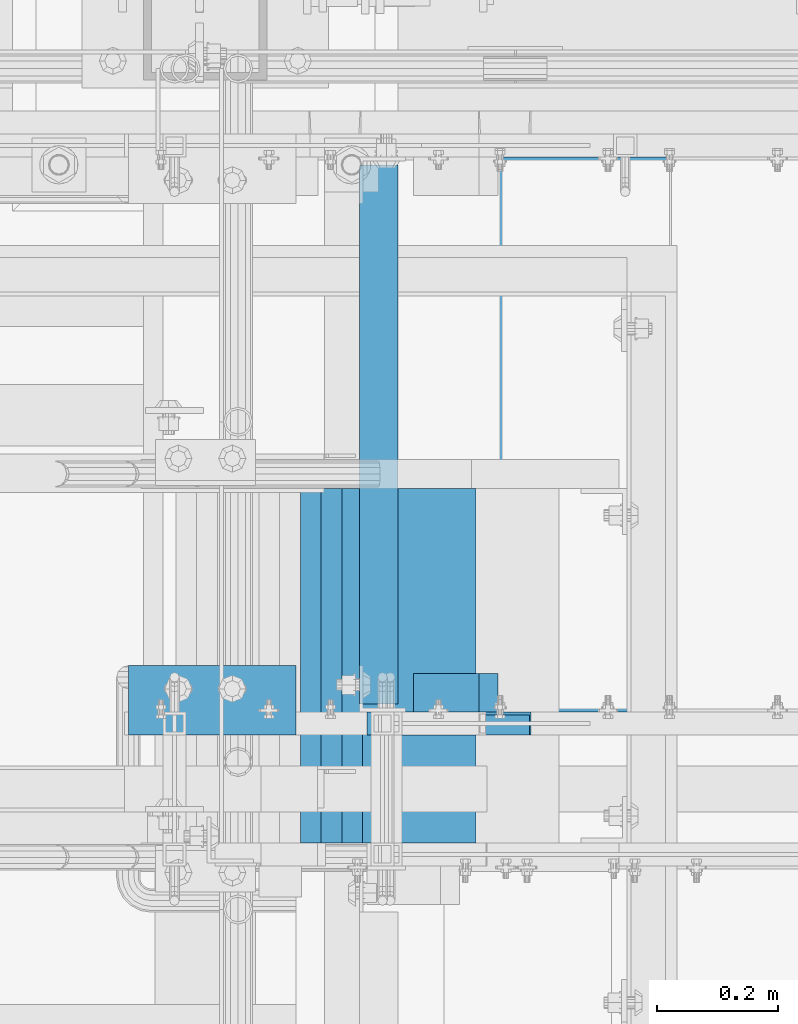
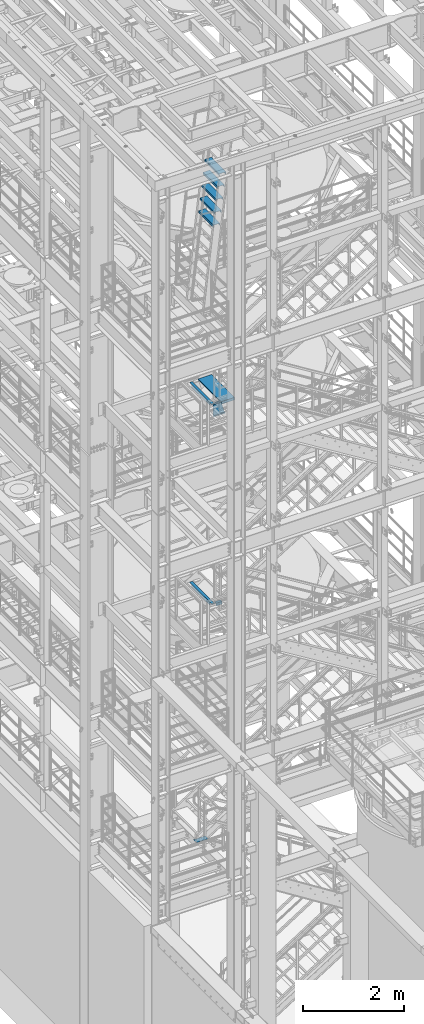
# One storey, part 1168 of 1876: 12 beams, 6 elements without a shape of their own.
"""IFC2X3 building model written with IfcOpenShell, lengths in millimetres."""

from ifc_helpers import new_model, si_unit, frame, origin_with_axes, place, context, subcontext, project, spatial, faceted_brep, material, type_object, element, aggregate, save


model = new_model("IFC2X3")

# Units and contexts
model_context = context("Model", 3, precision=1e-05, world=origin_with_axes())
body_context = subcontext(model_context, "Body", "Model", "MODEL_VIEW")
ifc_project = project(units=[si_unit("LENGTHUNIT", "METRE", prefix="MILLI"), si_unit("AREAUNIT", "SQUARE_METRE"), si_unit("VOLUMEUNIT", "CUBIC_METRE"), si_unit("MASSUNIT", "GRAM", prefix="KILO"), si_unit("TIMEUNIT", "SECOND"), si_unit("PLANEANGLEUNIT", "RADIAN"), si_unit("SOLIDANGLEUNIT", "STERADIAN"), si_unit("THERMODYNAMICTEMPERATUREUNIT", "DEGREE_CELSIUS"), si_unit("LUMINOUSINTENSITYUNIT", "LUMEN")], contexts=[model_context])

# Site, building, storey
site_placement = place(None, origin_with_axes())
site = spatial("IfcSite", under=ifc_project, at=site_placement, CompositionType="ELEMENT")
building_placement = place(site_placement, origin_with_axes())
building = spatial("IfcBuilding", under=site, at=building_placement, Name="Undefined", CompositionType="ELEMENT")
storey_placement = place(building_placement, origin_with_axes())
storey = spatial("IfcBuildingStorey", under=building, at=storey_placement, Name="Undefined", CompositionType="ELEMENT", Elevation=0.0)

# Assembly, beam
assembly_1_placement = place(storey_placement, origin_with_axes())
assembly_1 = element("IfcElementAssembly", 1, at=assembly_1_placement, inside=storey, Name="STRINGER", AssemblyPlace="NOTDEFINED", PredefinedType="RIGID_FRAME")
ifc_material = material(Name="STEEL/A36")
beam_type_1 = type_object("IfcBeamType", Name="L2-1/2X2-1/2X1/4", PredefinedType="NOTDEFINED")
beam_1_placement = place(assembly_1_placement, frame((2178.05007328855, -5683.25000115264, 15531.2768519598), z_axis=(0.0, 1.0, 0.0), x_axis=(-1.0, 0.0, 0.0)))
beam_1 = element("IfcBeam", 2, at=beam_1_placement, type_object=beam_type_1, material=ifc_material, Name="STRINGER", ObjectType="L2-1/2X2-1/2X1/4", context=body_context, shape_type="Brep", body=[
    faceted_brep([(0.0, 31.75, -31.75), (0.0, 31.75, 31.75), (107.95007324219, 31.7500000000491, 31.75), (107.95007324219, 31.7500000000491, -31.75), (0.0, 25.3999999999996, 31.75), (107.950073242189, 25.4000000000487, 31.75), (0.0, 25.3999999999996, -25.3999999999996), (107.950073242189, 25.4000000000487, -25.3999999999996), (0.0, -31.75, -25.3999999999996), (107.950073242189, -31.7499999999509, -25.3999999999996), (0.0, -31.75, -31.75), (107.950073242189, -31.7499999999509, -31.75)], [[[0, 1, 2, 3]], [[1, 4, 5, 2]], [[4, 6, 7, 5]], [[6, 8, 9, 7]], [[8, 10, 11, 9]], [[10, 0, 3, 11]], [[5, 7, 9, 11, 3, 2]], [[10, 8, 6, 4, 1, 0]]]),
])

assembly_2_placement = place(storey_placement, origin_with_axes())
assembly_2 = element("IfcElementAssembly", 3, at=assembly_2_placement, inside=storey, Name="STRINGER", AssemblyPlace="NOTDEFINED", PredefinedType="RIGID_FRAME")
beam_2_placement = place(assembly_2_placement, frame((2012.95, -4813.30000114601, 15531.3367791615), z_axis=(0.0, 0.0, -1.0), x_axis=(0.0, -1.0, 0.0)))
beam_2 = element("IfcBeam", 4, at=beam_2_placement, type_object=beam_type_1, material=ifc_material, Name="STRINGER", ObjectType="L2-1/2X2-1/2X1/4", context=body_context, shape_type="Brep", body=[
    faceted_brep([(76.1999938964764, 25.4000000000001, -19.0499992370624), (76.1999938964764, 31.75, -19.0499992370624), (0.0, 31.75, -19.0499992370605), (0.0, 25.4000000000001, -19.0499992370605), (76.1999938964791, 25.4000000000001, 31.7499999999982), (76.1999938964791, 31.75, 31.75), (0.0, 25.3999999999996, -25.3999999999996), (0.0, -31.75, -25.3999999999996), (889.000000006634, -31.75, -25.3999999999996), (889.000000006634, 25.4000000000001, -25.3999999999996), (0.0, -31.75, -31.75), (889.000000006634, -31.75, -31.75), (0.0, 31.75, -31.75), (889.000000006634, 31.75, -31.75), (889.000000006634, 31.75, -19.0499992370569), (889.000000006633, 25.4000000000001, -19.0499992370569), (812.800003058393, 31.75, -19.0499992370569), (812.800003058393, 25.4000000000001, -19.0499992370569), (812.800003058393, 25.4000000000001, 31.75), (812.800003058393, 31.75, 31.75)], [[[0, 1, 2, 3]], [[4, 5, 1, 0]], [[6, 7, 8, 9]], [[7, 10, 11, 8]], [[10, 12, 13, 11]], [[9, 8, 11, 13, 14, 15]], [[15, 14, 16, 17]], [[18, 17, 16, 19]], [[3, 6, 9, 15, 17, 18, 4, 0]], [[12, 10, 7, 6, 3, 2]], [[19, 16, 14, 13, 12, 2, 1, 5]], [[18, 19, 5, 4]]]),
])
aggregate(assembly_2, [beam_2])

assembly_3_placement = place(storey_placement, origin_with_axes())
assembly_3 = element("IfcElementAssembly", 5, at=assembly_3_placement, inside=storey, Name="STRINGER", AssemblyPlace="NOTDEFINED", PredefinedType="RIGID_FRAME")
beam_3_placement = place(assembly_3_placement, frame((2209.80007358444, -5683.25000115213, 10702.925), z_axis=(0.0, 1.0, 0.0), x_axis=(-1.0, 0.0, 0.0)))
beam_3 = element("IfcBeam", 6, at=beam_3_placement, type_object=beam_type_1, material=ifc_material, Name="ANGLE", ObjectType="L2-1/2X2-1/2X1/4", context=body_context, shape_type="Brep", body=[
    faceted_brep([(0.0, 31.75, -31.75), (0.0, 31.75, 31.75), (139.700073242188, 31.75, 31.75), (139.700073242188, 31.75, -31.75), (0.0, 25.3999999999996, 31.75), (139.700073242188, 25.3999999999996, 31.75), (0.0, 25.3999999999996, -25.3999999999996), (139.700073242188, 25.3999999999996, -25.3999999999996), (0.0, -31.75, -25.3999999999996), (139.700073242188, -31.75, -25.3999999999996), (0.0, -31.75, -31.75), (139.700073242188, -31.75, -31.75)], [[[0, 1, 2, 3]], [[1, 4, 5, 2]], [[4, 6, 7, 5]], [[6, 8, 9, 7]], [[8, 10, 11, 9]], [[10, 0, 3, 11]], [[5, 7, 9, 11, 3, 2]], [[10, 8, 6, 4, 1, 0]]]),
])
aggregate(assembly_3, [beam_3])

assembly_4_placement = place(storey_placement, origin_with_axes())
assembly_4 = element("IfcElementAssembly", 7, at=assembly_4_placement, inside=storey, Name="STRINGER", AssemblyPlace="NOTDEFINED", PredefinedType="RIGID_FRAME")
beam_4_placement = place(assembly_4_placement, frame((2012.95000034225, -4813.3000011455, 10702.925), z_axis=(0.0, 0.0, -1.0), x_axis=(0.0, -1.0, 0.0)))
beam_4 = element("IfcBeam", 8, at=beam_4_placement, type_object=beam_type_1, material=ifc_material, Name="STRINGER", ObjectType="L2-1/2X2-1/2X1/4", context=body_context, shape_type="Brep", body=[
    faceted_brep([(76.1999938964764, 25.4000000000001, -19.0499992370624), (76.1999938964764, 31.75, -19.0499992370624), (0.0, 31.75, -19.0499992370605), (0.0, 25.4000000000001, -19.0499992370605), (76.1999938964791, 25.4000000000001, 31.7499999999982), (76.1999938964791, 31.75, 31.75), (0.0, 25.3999999999996, -25.3999999999996), (0.0, -31.75, -25.3999999999996), (889.000000006634, -31.75, -25.3999999999996), (889.000000006634, 25.4000000000001, -25.3999999999996), (0.0, -31.75, -31.75), (889.000000006634, -31.75, -31.75), (0.0, 31.75, -31.75), (889.000000006634, 31.75, -31.75), (889.000000006634, 31.75, -19.0499992370569), (889.000000006633, 25.4000000000001, -19.0499992370569), (812.800003058393, 31.75, -19.0499992370569), (812.800003058393, 25.4000000000001, -19.0499992370569), (812.800003058393, 25.4000000000001, 31.75), (812.800003058393, 31.75, 31.75)], [[[0, 1, 2, 3]], [[4, 5, 1, 0]], [[6, 7, 8, 9]], [[7, 10, 11, 8]], [[10, 12, 13, 11]], [[9, 8, 11, 13, 14, 15]], [[15, 14, 16, 17]], [[18, 17, 16, 19]], [[3, 6, 9, 15, 17, 18, 4, 0]], [[12, 10, 7, 6, 3, 2]], [[19, 16, 14, 13, 12, 2, 1, 5]], [[18, 19, 5, 4]]]),
])
aggregate(assembly_4, [beam_4])

# Beam
beam_type_2 = type_object("IfcBeamType", PredefinedType="NOTDEFINED")
beam_5_placement = place(assembly_1_placement, frame((2338.38750025482, -4805.36200114421, 15559.8518518519), z_axis=(-1.0, 0.0, 0.0), x_axis=(0.0, -1.0, 0.0)))
beam_5 = element("IfcBeam", 9, at=beam_5_placement, type_object=beam_type_2, material=ifc_material, Name="TREAD", context=body_context, shape_type="Brep", body=[
    faceted_brep([(-4.76199999866458, -53.9750000000076, -153.987499894642), (-4.76199999866458, -53.9750000000076, 153.987506208874), (-4.76199999866458, 9.52499999999782, 153.987536726452), (-4.76199999866458, 9.52499999999236, -153.987499894642), (1.33604771690443e-09, -53.9750000000076, -153.987499894642), (1.33604771690443e-09, -53.9750000000076, 153.987506208874), (1.33604771690443e-09, -9.52499999999964, -153.987499894642), (-7.45785655453801e-11, -9.52500000019427, 153.987536621094), (909.637999997837, 9.52499999999236, -153.987499894642), (0.0, 9.52499999999964, 153.9875), (909.637999997837, 9.52499999999236, 153.987506208874), (909.637999997837, -53.9750000000076, -153.987499894642), (904.875999997837, -53.9750000000076, -153.987499894642), (904.875999997837, -9.52499999999964, -153.9875), (904.875999997837, -9.52499999999964, 153.987506208874), (904.875999997837, -53.9750000000076, 153.987506208874), (909.637999997837, -53.9750000000076, 153.987506208874)], [[[0, 1, 2, 3]], [[1, 0, 4, 5]], [[5, 4, 6, 7]], [[8, 3, 2, 9, 10]], [[11, 12, 13, 6, 4, 0, 3, 8]], [[14, 7, 6, 13]], [[15, 12, 11, 16]], [[12, 15, 14, 13]], [[16, 11, 8, 10]], [[9, 2, 1, 5, 7, 14, 15, 16, 10]]]),
])

# Assembly, beams
assembly_5_placement = place(storey_placement, origin_with_axes())
assembly_5 = element("IfcElementAssembly", 10, at=assembly_5_placement, inside=storey, Name="RIGHT STRINGER", AssemblyPlace="NOTDEFINED", PredefinedType="RIGID_FRAME")
beam_type_3 = type_object("IfcBeamType", PredefinedType="NOTDEFINED")
beam_6_placement = place(assembly_5_placement, frame((2096.93570416699, -5930.9, 21240.75), z_axis=(1.0, 0.0, 0.0), x_axis=(0.0, 1.0, 0.0)))
beam_6 = element("IfcBeam", 11, at=beam_6_placement, type_object=beam_type_3, material=ifc_material, Name="TREAD", context=body_context, shape_type="Brep", body=[
    faceted_brep([(0.0, -25.4000000000015, -76.1999999999998), (0.0, 25.4000000000015, -76.1999999999998), (584.199999999999, 25.4000000000015, -76.1999999999998), (584.199999999999, -25.4000000000015, -76.1999999999998), (0.0, 25.4000000000015, 76.1999999999998), (584.199999999999, 25.4000000000015, 76.1999999999998), (0.0, -25.4000000000015, 76.1999999999998), (584.199999999999, -25.4000000000015, 76.1999999999998), (0.0, -25.4000000000015, 63.5), (584.199999999999, -25.4000000000015, 63.5), (0.0, -22.2249999999985, 63.5), (584.199999999999, -22.2249999999985, 63.5), (0.0, -22.2249999999985, 73.0250000000001), (584.199999999999, -22.2249999999985, 73.0250000000001), (0.0, 22.2249999999985, 73.0250000000001), (584.199999999999, 22.2249999999985, 73.0250000000001), (0.0, 22.2249999999985, -73.0250000000001), (584.199999999999, 22.2249999999985, -73.0250000000001), (0.0, -22.2249999999985, -73.0250000000001), (584.199999999999, -22.2249999999985, -73.0250000000001), (0.0, -22.2249999999985, -63.5), (584.199999999999, -22.2249999999985, -63.5), (0.0, -25.4000000000015, -63.5), (584.199999999999, -25.4000000000015, -63.5)], [[[0, 1, 2, 3]], [[1, 4, 5, 2]], [[4, 6, 7, 5]], [[6, 8, 9, 7]], [[8, 10, 11, 9]], [[10, 12, 13, 11]], [[12, 14, 15, 13]], [[14, 16, 17, 15]], [[16, 18, 19, 17]], [[18, 20, 21, 19]], [[20, 22, 23, 21]], [[22, 0, 3, 23]], [[5, 7, 9, 11, 13, 15, 17, 19, 21, 23, 3, 2]], [[22, 20, 18, 16, 14, 12, 10, 8, 6, 4, 1, 0]]]),
])
beam_7_placement = place(assembly_5_placement, frame((2062.74609469726, -5930.9, 20942.3), z_axis=(1.0, 0.0, 0.0), x_axis=(0.0, 1.0, 0.0)))
beam_7 = element("IfcBeam", 12, at=beam_7_placement, type_object=beam_type_3, material=ifc_material, Name="TREAD", context=body_context, shape_type="Brep", body=[
    faceted_brep([(0.0, -25.4000000000015, -76.1999999999998), (0.0, 25.4000000000015, -76.1999999999998), (584.199999999999, 25.4000000000015, -76.1999999999998), (584.199999999999, -25.4000000000015, -76.1999999999998), (0.0, 25.4000000000015, 76.1999999999998), (584.199999999999, 25.4000000000015, 76.1999999999998), (0.0, -25.4000000000015, 76.1999999999998), (584.199999999999, -25.4000000000015, 76.1999999999998), (0.0, -25.4000000000015, 63.5), (584.199999999999, -25.4000000000015, 63.5), (0.0, -22.2249999999985, 63.5), (584.199999999999, -22.2249999999985, 63.5), (0.0, -22.2249999999985, 73.0250000000001), (584.199999999999, -22.2249999999985, 73.0250000000001), (0.0, 22.2249999999985, 73.0250000000001), (584.199999999999, 22.2249999999985, 73.0250000000001), (0.0, 22.2249999999985, -73.0250000000001), (584.199999999999, 22.2249999999985, -73.0250000000001), (0.0, -22.2249999999985, -73.0250000000001), (584.199999999999, -22.2249999999985, -73.0250000000001), (0.0, -22.2249999999985, -63.5), (584.199999999999, -22.2249999999985, -63.5), (0.0, -25.4000000000015, -63.5), (584.199999999999, -25.4000000000015, -63.5)], [[[0, 1, 2, 3]], [[1, 4, 5, 2]], [[4, 6, 7, 5]], [[6, 8, 9, 7]], [[8, 10, 11, 9]], [[10, 12, 13, 11]], [[12, 14, 15, 13]], [[14, 16, 17, 15]], [[16, 18, 19, 17]], [[18, 20, 21, 19]], [[20, 22, 23, 21]], [[22, 0, 3, 23]], [[5, 7, 9, 11, 13, 15, 17, 19, 21, 23, 3, 2]], [[22, 20, 18, 16, 14, 12, 10, 8, 6, 4, 1, 0]]]),
])
beam_8_placement = place(assembly_5_placement, frame((2028.55648522754, -5930.9, 20643.85), z_axis=(1.0, 0.0, 0.0), x_axis=(0.0, 1.0, 0.0)))
beam_8 = element("IfcBeam", 13, at=beam_8_placement, type_object=beam_type_3, material=ifc_material, Name="TREAD", context=body_context, shape_type="Brep", body=[
    faceted_brep([(0.0, -25.4000000000015, -76.1999999999998), (0.0, 25.4000000000015, -76.1999999999998), (584.199999999999, 25.4000000000015, -76.1999999999998), (584.199999999999, -25.4000000000015, -76.1999999999998), (0.0, 25.4000000000015, 76.1999999999998), (584.199999999999, 25.4000000000015, 76.1999999999998), (0.0, -25.4000000000015, 76.1999999999998), (584.199999999999, -25.4000000000015, 76.1999999999998), (0.0, -25.4000000000015, 63.5), (584.199999999999, -25.4000000000015, 63.5), (0.0, -22.2249999999985, 63.5), (584.199999999999, -22.2249999999985, 63.5), (0.0, -22.2249999999985, 73.0250000000001), (584.199999999999, -22.2249999999985, 73.0250000000001), (0.0, 22.2249999999985, 73.0250000000001), (584.199999999999, 22.2249999999985, 73.0250000000001), (0.0, 22.2249999999985, -73.0250000000001), (584.199999999999, 22.2249999999985, -73.0250000000001), (0.0, -22.2249999999985, -73.0250000000001), (584.199999999999, -22.2249999999985, -73.0250000000001), (0.0, -22.2249999999985, -63.5), (584.199999999999, -22.2249999999985, -63.5), (0.0, -25.4000000000015, -63.5), (584.199999999999, -25.4000000000015, -63.5)], [[[0, 1, 2, 3]], [[1, 4, 5, 2]], [[4, 6, 7, 5]], [[6, 8, 9, 7]], [[8, 10, 11, 9]], [[10, 12, 13, 11]], [[12, 14, 15, 13]], [[14, 16, 17, 15]], [[16, 18, 19, 17]], [[18, 20, 21, 19]], [[20, 22, 23, 21]], [[22, 0, 3, 23]], [[5, 7, 9, 11, 13, 15, 17, 19, 21, 23, 3, 2]], [[22, 20, 18, 16, 14, 12, 10, 8, 6, 4, 1, 0]]]),
])
beam_9_placement = place(assembly_5_placement, frame((1994.36687575781, -5930.9, 20345.4), z_axis=(1.0, 0.0, 0.0), x_axis=(0.0, 1.0, 0.0)))
beam_9 = element("IfcBeam", 14, at=beam_9_placement, type_object=beam_type_3, material=ifc_material, Name="TREAD", context=body_context, shape_type="Brep", body=[
    faceted_brep([(0.0, -25.4000000000015, -76.1999999999998), (0.0, 25.4000000000015, -76.1999999999998), (584.199999999999, 25.4000000000015, -76.1999999999998), (584.199999999999, -25.4000000000015, -76.1999999999998), (0.0, 25.4000000000015, 76.1999999999998), (584.199999999999, 25.4000000000015, 76.1999999999998), (0.0, -25.4000000000015, 76.1999999999998), (584.199999999999, -25.4000000000015, 76.1999999999998), (0.0, -25.4000000000015, 63.5), (584.199999999999, -25.4000000000015, 63.5), (0.0, -22.2249999999985, 63.5), (584.199999999999, -22.2249999999985, 63.5), (0.0, -22.2249999999985, 73.0250000000001), (584.199999999999, -22.2249999999985, 73.0250000000001), (0.0, 22.2249999999985, 73.0250000000001), (584.199999999999, 22.2249999999985, 73.0250000000001), (0.0, 22.2249999999985, -73.0250000000001), (584.199999999999, 22.2249999999985, -73.0250000000001), (0.0, -22.2249999999985, -73.0250000000001), (584.199999999999, -22.2249999999985, -73.0250000000001), (0.0, -22.2249999999985, -63.5), (584.199999999999, -22.2249999999985, -63.5), (0.0, -25.4000000000015, -63.5), (584.199999999999, -25.4000000000015, -63.5)], [[[0, 1, 2, 3]], [[1, 4, 5, 2]], [[4, 6, 7, 5]], [[6, 8, 9, 7]], [[8, 10, 11, 9]], [[10, 12, 13, 11]], [[12, 14, 15, 13]], [[14, 16, 17, 15]], [[16, 18, 19, 17]], [[18, 20, 21, 19]], [[20, 22, 23, 21]], [[22, 0, 3, 23]], [[5, 7, 9, 11, 13, 15, 17, 19, 21, 23, 3, 2]], [[22, 20, 18, 16, 14, 12, 10, 8, 6, 4, 1, 0]]]),
])
beam_10_placement = place(assembly_5_placement, frame((1960.17726628808, -5930.9, 20046.95), z_axis=(1.0, 0.0, 0.0), x_axis=(0.0, 1.0, 0.0)))
beam_10 = element("IfcBeam", 15, at=beam_10_placement, type_object=beam_type_3, material=ifc_material, Name="TREAD", context=body_context, shape_type="Brep", body=[
    faceted_brep([(0.0, -25.4000000000015, -76.1999999999998), (0.0, 25.4000000000015, -76.1999999999998), (584.199999999999, 25.4000000000015, -76.1999999999998), (584.199999999999, -25.4000000000015, -76.1999999999998), (0.0, 25.4000000000015, 76.1999999999998), (584.199999999999, 25.4000000000015, 76.1999999999998), (0.0, -25.4000000000015, 76.1999999999998), (584.199999999999, -25.4000000000015, 76.1999999999998), (0.0, -25.4000000000015, 63.5), (584.199999999999, -25.4000000000015, 63.5), (0.0, -22.2249999999985, 63.5), (584.199999999999, -22.2249999999985, 63.5), (0.0, -22.2249999999985, 73.0250000000001), (584.199999999999, -22.2249999999985, 73.0250000000001), (0.0, 22.2249999999985, 73.0250000000001), (584.199999999999, 22.2249999999985, 73.0250000000001), (0.0, 22.2249999999985, -73.0250000000001), (584.199999999999, 22.2249999999985, -73.0250000000001), (0.0, -22.2249999999985, -73.0250000000001), (584.199999999999, -22.2249999999985, -73.0250000000001), (0.0, -22.2249999999985, -63.5), (584.199999999999, -22.2249999999985, -63.5), (0.0, -25.4000000000015, -63.5), (584.199999999999, -25.4000000000015, -63.5)], [[[0, 1, 2, 3]], [[1, 4, 5, 2]], [[4, 6, 7, 5]], [[6, 8, 9, 7]], [[8, 10, 11, 9]], [[10, 12, 13, 11]], [[12, 14, 15, 13]], [[14, 16, 17, 15]], [[16, 18, 19, 17]], [[18, 20, 21, 19]], [[20, 22, 23, 21]], [[22, 0, 3, 23]], [[5, 7, 9, 11, 13, 15, 17, 19, 21, 23, 3, 2]], [[22, 20, 18, 16, 14, 12, 10, 8, 6, 4, 1, 0]]]),
])
aggregate(assembly_5, [beam_6, beam_7, beam_8, beam_9, beam_10])

# Assembly, beam
assembly_6_placement = place(storey_placement, origin_with_axes())
assembly_6 = element("IfcElementAssembly", 16, at=assembly_6_placement, inside=storey, Name="STRINGER", AssemblyPlace="NOTDEFINED", PredefinedType="RIGID_FRAME")
beam_type_4 = type_object("IfcBeamType", PredefinedType="NOTDEFINED")
beam_11_placement = place(assembly_6_placement, frame((1876.42499918269, -5695.95000113592, 5133.97499991051), z_axis=(0.0, -1.0, 0.0), x_axis=(-1.0, 0.0, 0.0)))
beam_11 = element("IfcBeam", 17, at=beam_11_placement, type_object=beam_type_4, material=ifc_material, Name="PLATE", context=body_context, shape_type="Brep", body=[
    faceted_brep([(0.0, 3.17499999999927, -57.1499999999996), (0.0, 3.17499999999927, 57.1499999999996), (276.225, 3.17500000000018, 57.1499999999996), (276.225, 3.17500000000018, -57.1499999999996), (0.0, -3.17499999999927, 57.1499999999996), (276.225, -3.17500000000018, 57.1499999999996), (0.0, -3.17499999999927, -57.1499999999996), (276.225, -3.17500000000018, -57.1499999999996)], [[[0, 1, 2, 3]], [[1, 4, 5, 2]], [[4, 6, 7, 5]], [[6, 0, 3, 7]], [[5, 7, 3, 2]], [[6, 4, 1, 0]]]),
])
aggregate(assembly_6, [beam_11])

# Beam
beam_type_5 = type_object("IfcBeamType", Name="MC12X10.6", PredefinedType="NOTDEFINED")
beam_12_placement = place(assembly_1_placement, frame((1981.19999396601, -5734.05000114549, 15442.3768514434), z_axis=(0.0, 0.0, 1.0), x_axis=(1.0, 0.0, 0.0)))
beam_12 = element("IfcBeam", 18, at=beam_12_placement, type_object=beam_type_5, material=ifc_material, Name="STRINGER", ObjectType="MC12X10.6", context=body_context, shape_type="Brep", body=[
    faceted_brep([(12.7000060338987, 19.0500000000002, -152.4), (12.7000060338987, 19.0500000000002, 152.4), (195.969556105321, 19.0500000000002, 152.4), (282.73488299088, 19.0500000000002, -152.4), (12.7000060338987, -19.0500000000002, 152.4), (195.969556105321, -19.0500000000002, 152.4), (12.7000060338987, -19.0500000000002, 144.841595), (198.121155450985, -19.0500000000002, 144.841595), (12.7000060338987, 14.2875000000004, 144.17817875), (198.310005607784, 14.2875000000004, 144.17817875), (12.7000060338987, 14.2875000000004, -144.17817875), (280.394433488417, 14.2875000000004, -144.17817875), (12.7000060338987, -19.0500000000002, -144.841595), (280.583283645216, -19.0500000000002, -144.841595), (12.7000060338987, -19.0500000000002, -152.4), (282.73488299088, -19.0500000000002, -152.4)], [[[0, 1, 2, 3]], [[1, 4, 5, 2]], [[4, 6, 7, 5]], [[6, 8, 9, 7]], [[8, 10, 11, 9]], [[10, 12, 13, 11]], [[12, 14, 15, 13]], [[14, 0, 3, 15]], [[5, 7, 9, 11, 13, 15, 3, 2]], [[14, 12, 10, 8, 6, 4, 1, 0]]]),
])

aggregate(assembly_1, [beam_12, beam_5, beam_1])

save(model, "model.ifc")
